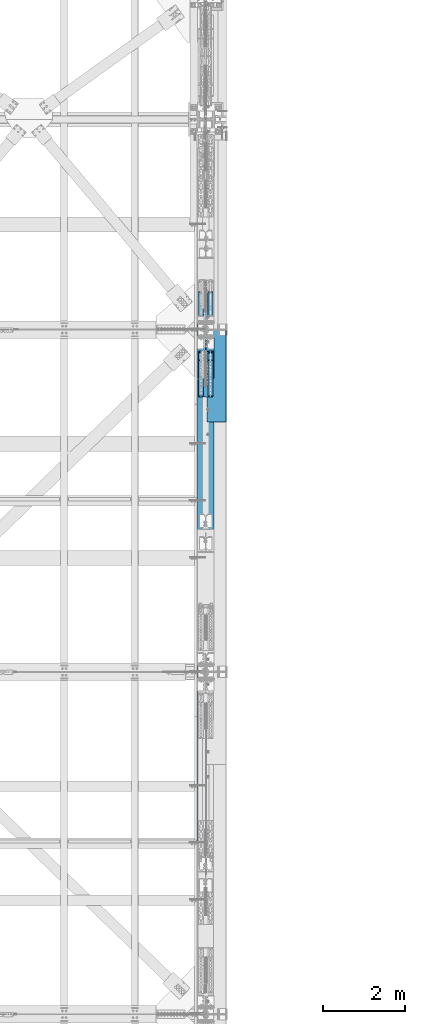
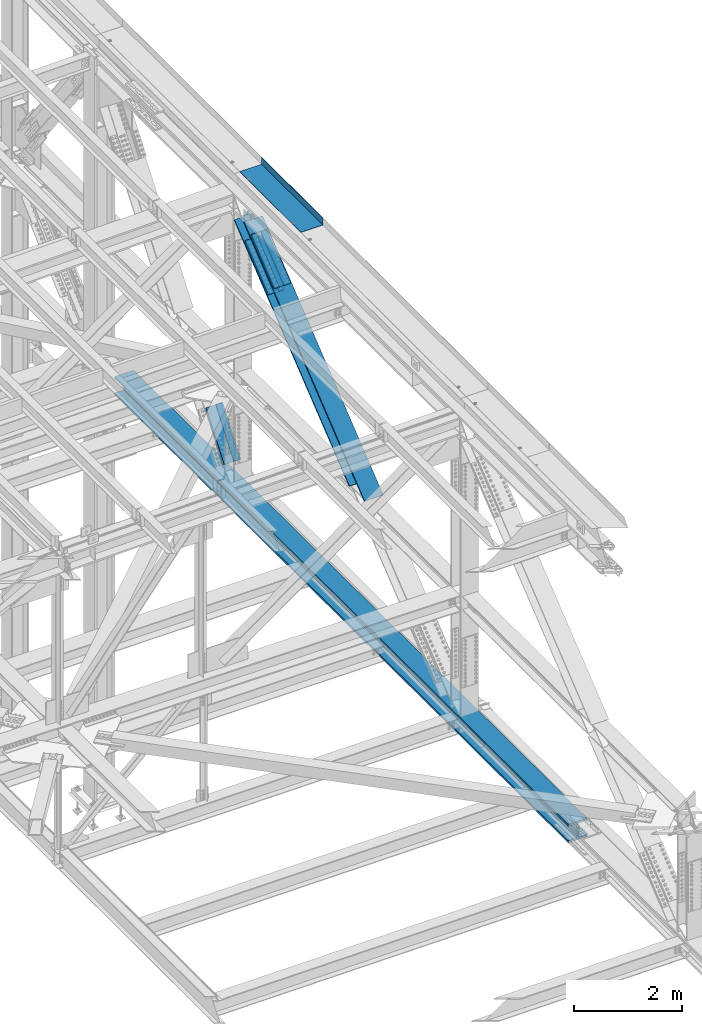
# One storey, part 1985 of 3843: 11 members, 2 beams, 4 elements without a shape of their own.
"""IFC2X3 building model written with IfcOpenShell, lengths in millimetres."""

from ifc_helpers import new_model, si_unit, frame, origin_with_axes, place, context, subcontext, project, spatial, faceted_brep, material, type_object, element, aggregate, save


model = new_model("IFC2X3")

# Units and contexts
model_context = context("Model", 3, precision=1e-05, world=origin_with_axes())
body_context = subcontext(model_context, "Body", "Model", "MODEL_VIEW")
ifc_project = project(units=[si_unit("LENGTHUNIT", "METRE", prefix="MILLI"), si_unit("AREAUNIT", "SQUARE_METRE"), si_unit("VOLUMEUNIT", "CUBIC_METRE"), si_unit("MASSUNIT", "GRAM", prefix="KILO"), si_unit("TIMEUNIT", "SECOND"), si_unit("PLANEANGLEUNIT", "RADIAN"), si_unit("SOLIDANGLEUNIT", "STERADIAN"), si_unit("THERMODYNAMICTEMPERATUREUNIT", "DEGREE_CELSIUS"), si_unit("LUMINOUSINTENSITYUNIT", "LUMEN")], contexts=[model_context])

# Site, building, storey
site_placement = place(None, origin_with_axes())
site = spatial("IfcSite", under=ifc_project, at=site_placement, CompositionType="ELEMENT")
building_placement = place(site_placement, origin_with_axes())
building = spatial("IfcBuilding", under=site, at=building_placement, Name="Undefined", CompositionType="ELEMENT")
storey_placement = place(building_placement, origin_with_axes())
storey = spatial("IfcBuildingStorey", under=building, at=storey_placement, Name="Undefined", CompositionType="ELEMENT", Elevation=0.0)

# Assembly, beam
assembly_1_placement = place(storey_placement, origin_with_axes())
assembly_1 = element("IfcElementAssembly", 1, at=assembly_1_placement, inside=storey, Name="BEAM", AssemblyPlace="NOTDEFINED", PredefinedType="RIGID_FRAME")
ifc_material_1 = material(Name="STEEL/A992")
beam_type_1 = type_object("IfcBeamType", Name="W14X257", PredefinedType="NOTDEFINED")
beam_1_placement = place(assembly_1_placement, frame((85648.8, 71449.7644305582, 39539.4404782484), z_axis=(0.0, 0.00349392500078829, 0.999993896225416), x_axis=(0.0, 0.999993896225416, -0.00349392500078778)))
beam_1 = element("IfcBeam", 2, at=beam_1_placement, type_object=beam_type_1, material=ifc_material_1, Name="BEAM", ObjectType="W14X257", context=body_context, shape_type="Brep", body=[
    faceted_brep([(13400.7918144194, -203.199999999997, 164.088281632765), (13400.7918144194, -15.0812500000029, 164.088281632765), (15075.9184465029, -15.0812500000029, 162.447245856085), (15075.9184465029, -203.199999999997, 162.447245856085), (11725.6647886285, -203.199999999997, 165.26045013847), (11725.6647886285, -15.0812500000029, 165.26045013847), (10050.537500366, -203.199999999997, 165.963751280062), (10050.537500366, -15.0812500000029, 165.963751280062), (8375.41008086779, -203.199999999997, 166.198185003552), (8375.41008086779, -15.0812500000029, 166.198185003552), (6700.28266136955, -203.199999999997, 165.963751289346), (6700.28266136955, -15.0812500000029, 165.963751289346), (5025.1553731071, -203.199999999997, 165.260450157024), (5025.1553731071, -15.0812500000029, 165.260450157024), (3350.02834731621, -203.199999999997, 164.088281660603), (3350.02834731621, -15.0812500000029, 164.088281660603), (1674.90171523266, -203.199999999997, 162.447245893207), (1674.90171523266, -15.0812500000029, 162.447245893207), (6.12560524529545, -203.199999999997, 160.345341113098), (6.12560524529545, -15.0812500000029, 160.345341113098), (13400.7918144194, 15.0812500000029, 164.088281632765), (13400.7918144194, 203.199999999997, 164.088281632765), (15075.9184465029, 203.199999999997, 162.447245856085), (15075.9184465029, 15.0812500000029, 162.447245856085), (11725.6647886285, 15.0812500000029, 165.26045013847), (11725.6647886285, 203.199999999997, 165.26045013847), (10050.537500366, 15.0812500000029, 165.963751280062), (10050.537500366, 203.199999999997, 165.963751280062), (8375.41008086779, 15.0812500000029, 166.198185003552), (8375.41008086779, 203.199999999997, 166.198185003552), (6700.28266136955, 15.0812500000029, 165.963751289346), (6700.28266136955, 203.199999999997, 165.963751289346), (5025.1553731071, 15.0812500000029, 165.260450157024), (5025.1553731071, 203.199999999997, 165.260450157024), (3350.02834731621, 15.0812500000029, 164.088281660603), (3350.02834731621, 203.199999999997, 164.088281660603), (1674.90171523266, 15.0812500000029, 162.447245893207), (1674.90171523266, 203.199999999997, 162.447245893207), (6.12560524529545, 15.0812500000029, 160.345341113098), (6.12560524529545, 203.199999999997, 160.345341113098), (13400.5225440723, 203.199999999997, -156.586605315169), (13400.5225440723, 15.0812500000029, -156.586605315169), (15075.5594194066, 15.0812500000029, -158.227553161756), (15075.5594194066, 203.199999999997, -158.227553161756), (11725.4852750518, 203.199999999997, -155.41449961668), (11725.4852750518, 15.0812500000029, -155.41449961668), (10050.4477435737, 203.199999999997, -154.711236159405), (10050.4477435737, 15.0812500000029, -154.711236159405), (8375.4100808669, 203.199999999997, -154.476814997368), (8375.4100808669, 15.0812500000029, -154.476814997368), (6700.37241816011, 203.199999999997, -154.71123615012), (6700.37241816011, 15.0812500000029, -154.71123615012), (5025.33488668206, 203.199999999997, -155.414499598119), (5025.33488668206, 15.0812500000029, -155.414499598119), (3350.29761766152, 203.199999999997, -156.586605287324), (3350.29761766152, 15.0812500000029, -156.586605287324), (1675.26074232721, 203.199999999997, -158.227553124634), (1675.26074232721, 15.0812500000029, -158.227553124634), (6.57438513686066, 203.199999999997, -160.329344856727), (6.57438513686066, 15.0812500000029, -160.329344856727), (13400.4825534267, -203.199999999997, -204.211588525264), (13400.4825534267, 203.199999999997, -204.211588525264), (15075.5060985507, 203.199999999997, -205.852523312911), (15075.5060985507, -203.199999999997, -205.852523312911), (11725.4586146196, -203.199999999997, -203.039492154574), (11725.4586146196, 203.199999999997, -203.039492154574), (10050.434413357, -203.199999999997, -202.336234293987), (10050.434413357, 203.199999999997, -202.336234293987), (8375.41008086677, -203.199999999997, -202.101814997499), (8375.41008086677, 203.199999999997, -202.101814997499), (6700.38574837653, -203.199999999997, -202.336234284703), (6700.38574837653, 203.199999999997, -202.336234284703), (5025.36154711401, -203.199999999997, -203.039492136013), (5025.36154711401, 203.199999999997, -203.039492136013), (3350.33760830687, -203.199999999997, -204.211588497419), (3350.33760830687, 203.199999999997, -204.211588497419), (1675.31406318286, -203.199999999997, -205.852523275797), (1675.31406318286, 203.199999999997, -205.852523275797), (6.64103561578668, -203.199999999997, -207.954298218574), (6.64103561578668, 203.199999999997, -207.954298218574), (13400.5225440723, -15.0812500000029, -156.586605315169), (13400.5225440723, -203.199999999997, -156.586605315169), (15075.5594194066, -203.199999999997, -158.227553161756), (15075.5594194066, -15.0812500000029, -158.227553161756), (11725.4852750518, -15.0812500000029, -155.41449961668), (11725.4852750518, -203.199999999997, -155.41449961668), (10050.4477435737, -15.0812500000029, -154.711236159405), (10050.4477435737, -203.199999999997, -154.711236159405), (8375.4100808669, -15.0812500000029, -154.476814997368), (8375.4100808669, -203.199999999997, -154.476814997368), (6700.37241816011, -15.0812500000029, -154.71123615012), (6700.37241816011, -203.199999999997, -154.71123615012), (5025.33488668206, -15.0812500000029, -155.414499598119), (5025.33488668206, -203.199999999997, -155.414499598119), (3350.29761766152, -15.0812500000029, -156.586605287324), (3350.29761766152, -203.199999999997, -156.586605287324), (1675.26074232721, -15.0812500000029, -158.227553124634), (1675.26074232721, -203.199999999997, -158.227553124634), (6.57438513686066, -15.0812500000029, -160.329344856727), (6.57438513686066, -203.199999999997, -160.329344856727), (6.05895476636942, -203.199999999997, 207.970294474952), (6.05895476636942, 203.199999999997, 207.970294474952), (1674.84839437701, -203.199999999997, 210.072216044369), (1674.84839437701, 203.199999999997, 210.072216044369), (3349.98835667086, -203.199999999997, 211.71326487069), (3349.98835667086, 203.199999999997, 211.71326487069), (5025.12871267518, -203.199999999997, 212.885442694918), (5025.12871267518, 203.199999999997, 212.885442694918), (6700.26933115313, -203.199999999997, 213.588749423921), (6700.26933115313, 203.199999999997, 213.588749423921), (8375.41008086794, -203.199999999997, 213.823185003683), (8375.41008086794, 203.199999999997, 213.823185003683), (10050.5508305827, -203.199999999997, 213.588749414637), (10050.5508305827, 203.199999999997, 213.588749414637), (11725.6914490607, -203.199999999997, 212.88544267635), (11725.6914490607, 203.199999999997, 212.88544267635), (13400.831805065, -203.199999999997, 211.713264842845), (13400.831805065, 203.199999999997, 211.713264842845), (15075.9717673588, -203.199999999997, 210.072216007247), (15075.9717673588, 203.199999999997, 210.072216007247), (16744.7612150182, -203.199999999997, 207.970294418446), (16744.7612150182, 203.199999999997, 207.970294418446), (16744.6945213029, 203.199999999997, 160.345341111053), (16744.6945213029, 15.0812500000029, 160.345341111053), (16744.2454502866, 15.0812500000029, -160.329344492086), (16744.2454502866, 203.199999999997, -160.329344492086), (16744.1787565713, 203.199999999997, -207.954297799486), (16744.1787565713, -203.199999999997, -207.954297799486), (16744.2454502866, -203.199999999997, -160.329344492086), (16744.2454502866, -15.0812500000029, -160.329344492086), (16744.6945213029, -15.0812500000029, 160.345341111053), (16744.6945213029, -203.199999999997, 160.345341111053)], [[[0, 1, 2, 3]], [[4, 5, 1, 0]], [[6, 7, 5, 4]], [[8, 9, 7, 6]], [[10, 11, 9, 8]], [[12, 13, 11, 10]], [[14, 15, 13, 12]], [[16, 17, 15, 14]], [[17, 16, 18, 19]], [[20, 21, 22, 23]], [[24, 25, 21, 20]], [[26, 27, 25, 24]], [[28, 29, 27, 26]], [[30, 31, 29, 28]], [[32, 33, 31, 30]], [[34, 35, 33, 32]], [[36, 37, 35, 34]], [[37, 36, 38, 39]], [[40, 41, 42, 43]], [[44, 45, 41, 40]], [[46, 47, 45, 44]], [[48, 49, 47, 46]], [[50, 51, 49, 48]], [[52, 53, 51, 50]], [[54, 55, 53, 52]], [[56, 57, 55, 54]], [[57, 56, 58, 59]], [[60, 61, 62, 63]], [[64, 65, 61, 60]], [[66, 67, 65, 64]], [[68, 69, 67, 66]], [[70, 71, 69, 68]], [[72, 73, 71, 70]], [[74, 75, 73, 72]], [[76, 77, 75, 74]], [[77, 76, 78, 79]], [[80, 81, 82, 83]], [[84, 85, 81, 80]], [[86, 87, 85, 84]], [[88, 89, 87, 86]], [[90, 91, 89, 88]], [[92, 93, 91, 90]], [[94, 95, 93, 92]], [[96, 97, 95, 94]], [[97, 96, 98, 99]], [[19, 18, 100, 101, 39, 38, 59, 58, 79, 78, 99, 98]], [[102, 103, 101, 100]], [[103, 102, 104, 105]], [[105, 104, 106, 107]], [[107, 106, 108, 109]], [[109, 108, 110, 111]], [[111, 110, 112, 113]], [[113, 112, 114, 115]], [[115, 114, 116, 117]], [[117, 116, 118, 119]], [[119, 118, 120, 121]], [[22, 21, 25, 27, 29, 31, 33, 35, 37, 39, 101, 103, 105, 107, 109, 111, 113, 115, 117, 119, 121, 122]], [[23, 22, 122, 123]], [[42, 41, 45, 47, 49, 51, 53, 55, 57, 59, 38, 36, 34, 32, 30, 28, 26, 24, 20, 23, 123, 124]], [[43, 42, 124, 125]], [[62, 61, 65, 67, 69, 71, 73, 75, 77, 79, 58, 56, 54, 52, 50, 48, 46, 44, 40, 43, 125, 126]], [[63, 62, 126, 127]], [[82, 81, 85, 87, 89, 91, 93, 95, 97, 99, 78, 76, 74, 72, 70, 68, 66, 64, 60, 63, 127, 128]], [[83, 82, 128, 129]], [[2, 1, 5, 7, 9, 11, 13, 15, 17, 19, 98, 96, 94, 92, 90, 88, 86, 84, 80, 83, 129, 130]], [[3, 2, 130, 131]], [[118, 116, 114, 112, 110, 108, 106, 104, 102, 100, 18, 16, 14, 12, 10, 8, 6, 4, 0, 3, 131, 120]], [[130, 129, 128, 127, 126, 125, 124, 123, 122, 121, 120, 131]]]),
])

# Assembly, members
assembly_2_placement = place(storey_placement, origin_with_axes())
assembly_2 = element("IfcElementAssembly", 3, at=assembly_2_placement, inside=storey, Name="BEAM", AssemblyPlace="NOTDEFINED", PredefinedType="RIGID_FRAME")
ifc_material_2 = material(Name="STEEL/A572-50")
member_type_1 = type_object("IfcMemberType", PredefinedType="NOTDEFINED")
member_1_placement = place(assembly_2_placement, frame((85763.1, 82563.2250123025, 44935.1767413968), z_axis=(-1.0, 0.0, 0.0), x_axis=(0.0, 0.778233356622216, 0.627975192695157)))
member_1 = element("IfcMember", 4, at=member_1_placement, type_object=member_type_1, material=ifc_material_2, Name="PLATE", context=body_context, shape_type="Brep", body=[
    faceted_brep([(-4.36557456851006e-11, 12.7000000000116, -63.5), (-4.36557456851006e-11, 12.7000000000116, 63.5), (1104.90000001677, 12.7000000017251, 63.5), (1104.90000001677, 12.7000000017251, -63.5), (1.45519152283669e-11, -12.700000000008, 63.5), (1104.90000001682, -12.6999999982909, 63.5), (1.45519152283669e-11, -12.700000000008, -63.5), (1104.90000001682, -12.6999999982909, -63.5)], [[[0, 1, 2, 3]], [[1, 4, 5, 2]], [[4, 6, 7, 5]], [[6, 0, 3, 7]], [[5, 7, 3, 2]], [[6, 4, 1, 0]]]),
])
member_2_placement = place(assembly_2_placement, frame((85763.1, 82377.7996372957, 45164.9695957562), z_axis=(-1.0, 0.0, 0.0), x_axis=(0.0, 0.778233356622216, 0.627975192695157)))
member_2 = element("IfcMember", 5, at=member_2_placement, type_object=member_type_1, material=ifc_material_2, Name="PLATE", context=body_context, shape_type="Brep", body=[
    faceted_brep([(-4.36557456851006e-11, 12.7000000000116, -63.5), (-4.36557456851006e-11, 12.7000000000116, 63.5), (1104.90000001677, 12.7000000017251, 63.5), (1104.90000001677, 12.7000000017251, -63.5), (1.45519152283669e-11, -12.700000000008, 63.5), (1104.90000001682, -12.6999999982909, 63.5), (1.45519152283669e-11, -12.700000000008, -63.5), (1104.90000001682, -12.6999999982909, -63.5)], [[[0, 1, 2, 3]], [[1, 4, 5, 2]], [[4, 6, 7, 5]], [[6, 0, 3, 7]], [[5, 7, 3, 2]], [[6, 4, 1, 0]]]),
])
member_3_placement = place(assembly_2_placement, frame((85534.5, 82563.2250123025, 44935.1767413968), z_axis=(-1.0, 0.0, 0.0), x_axis=(0.0, 0.778233356622216, 0.627975192695157)))
member_3 = element("IfcMember", 6, at=member_3_placement, type_object=member_type_1, material=ifc_material_2, Name="PLATE", context=body_context, shape_type="Brep", body=[
    faceted_brep([(-4.36557456851006e-11, 12.7000000000116, -63.5), (-4.36557456851006e-11, 12.7000000000116, 63.5), (1104.90000001677, 12.7000000017251, 63.5), (1104.90000001677, 12.7000000017251, -63.5), (1.45519152283669e-11, -12.700000000008, 63.5), (1104.90000001682, -12.6999999982909, 63.5), (1.45519152283669e-11, -12.700000000008, -63.5), (1104.90000001682, -12.6999999982909, -63.5)], [[[0, 1, 2, 3]], [[1, 4, 5, 2]], [[4, 6, 7, 5]], [[6, 0, 3, 7]], [[5, 7, 3, 2]], [[6, 4, 1, 0]]]),
])
member_4_placement = place(assembly_2_placement, frame((85534.5, 82377.7996372957, 45164.9695957562), z_axis=(-1.0, 0.0, 0.0), x_axis=(0.0, 0.778233356622216, 0.627975192695157)))
member_4 = element("IfcMember", 7, at=member_4_placement, type_object=member_type_1, material=ifc_material_2, Name="PLATE", context=body_context, shape_type="Brep", body=[
    faceted_brep([(-4.36557456851006e-11, 12.7000000000116, -63.5), (-4.36557456851006e-11, 12.7000000000116, 63.5), (1104.90000001677, 12.7000000017251, 63.5), (1104.90000001677, 12.7000000017251, -63.5), (1.45519152283669e-11, -12.700000000008, 63.5), (1104.90000001682, -12.6999999982909, 63.5), (1.45519152283669e-11, -12.700000000008, -63.5), (1104.90000001682, -12.6999999982909, -63.5)], [[[0, 1, 2, 3]], [[1, 4, 5, 2]], [[4, 6, 7, 5]], [[6, 0, 3, 7]], [[5, 7, 3, 2]], [[6, 4, 1, 0]]]),
])

# Member
member_5_placement = place(assembly_1_placement, frame((85534.5, 84909.597305123, 40959.9479836651), z_axis=(1.0, 0.0, 0.0), x_axis=(0.0, -0.605220451019692, -0.796057916025914)))
member_5 = element("IfcMember", 8, at=member_5_placement, type_object=member_type_1, material=ifc_material_2, Name="PLATE", context=body_context, shape_type="Brep", body=[
    faceted_brep([(-4.36557456851006e-11, 12.7000000000116, -63.5), (-4.36557456851006e-11, 12.7000000000116, 63.5), (1104.90000001677, 12.7000000017251, 63.5), (1104.90000001677, 12.7000000017251, -63.5), (1.45519152283669e-11, -12.700000000008, 63.5), (1104.90000001682, -12.6999999982909, 63.5), (1.45519152283669e-11, -12.700000000008, -63.5), (1104.90000001682, -12.6999999982909, -63.5)], [[[0, 1, 2, 3]], [[1, 4, 5, 2]], [[4, 6, 7, 5]], [[6, 0, 3, 7]], [[5, 7, 3, 2]], [[6, 4, 1, 0]]]),
])

member_6_placement = place(assembly_1_placement, frame((85763.1, 84909.597305123, 40959.9479836651), z_axis=(1.0, 0.0, 0.0), x_axis=(0.0, -0.605220451019692, -0.796057916025914)))
member_6 = element("IfcMember", 9, at=member_6_placement, type_object=member_type_1, material=ifc_material_2, Name="PLATE", context=body_context, shape_type="Brep", body=[
    faceted_brep([(-4.36557456851006e-11, 12.7000000000116, -63.5), (-4.36557456851006e-11, 12.7000000000116, 63.5), (1104.90000001677, 12.7000000017251, 63.5), (1104.90000001677, 12.7000000017251, -63.5), (1.45519152283669e-11, -12.700000000008, 63.5), (1104.90000001682, -12.6999999982909, 63.5), (1.45519152283669e-11, -12.700000000008, -63.5), (1104.90000001682, -12.6999999982909, -63.5)], [[[0, 1, 2, 3]], [[1, 4, 5, 2]], [[4, 6, 7, 5]], [[6, 0, 3, 7]], [[5, 7, 3, 2]], [[6, 4, 1, 0]]]),
])

member_type_2 = type_object("IfcMemberType", PredefinedType="NOTDEFINED")
member_7_placement = place(assembly_2_placement, frame((85648.8, 83457.9869214133, 45585.7859388038), z_axis=(-1.0, 0.0, 0.0), x_axis=(0.0, -0.778233356622221, -0.62797519269515)))
member_7 = element("IfcMember", 10, at=member_7_placement, type_object=member_type_2, material=ifc_material_2, Name="PLATE", context=body_context, shape_type="Brep", body=[
    faceted_brep([(-1.45519152283669e-11, 12.7000000000025, -177.800000000003), (-1.45519152283669e-11, 12.7000000000025, 177.800000000003), (1104.90000001682, 12.7000000017051, 177.800000000003), (1104.90000001682, 12.7000000017051, -177.800000000003), (4.36557456851006e-11, -12.7000000000171, 177.800000000003), (1104.90000001686, -12.6999999983072, 177.800000000003), (4.36557456851006e-11, -12.7000000000171, -177.800000000003), (1104.90000001686, -12.6999999983072, -177.800000000003)], [[[0, 1, 2, 3]], [[1, 4, 5, 2]], [[4, 6, 7, 5]], [[6, 0, 3, 7]], [[5, 7, 3, 2]], [[6, 4, 1, 0]]]),
])

member_8_placement = place(assembly_2_placement, frame((85648.8, 83202.7778011492, 45902.059977359), z_axis=(-1.0, 0.0, 0.0), x_axis=(0.0, -0.778233356622221, -0.62797519269515)))
member_8 = element("IfcMember", 11, at=member_8_placement, type_object=member_type_2, material=ifc_material_2, Name="PLATE", context=body_context, shape_type="Brep", body=[
    faceted_brep([(-1.45519152283669e-11, 12.7000000000025, -177.800000000003), (-1.45519152283669e-11, 12.7000000000025, 177.800000000003), (1104.90000001682, 12.7000000017051, 177.800000000003), (1104.90000001682, 12.7000000017051, -177.800000000003), (4.36557456851006e-11, -12.7000000000171, 177.800000000003), (1104.90000001686, -12.6999999983072, 177.800000000003), (4.36557456851006e-11, -12.7000000000171, -177.800000000003), (1104.90000001686, -12.6999999983072, -177.800000000003)], [[[0, 1, 2, 3]], [[1, 4, 5, 2]], [[4, 6, 7, 5]], [[6, 0, 3, 7]], [[5, 7, 3, 2]], [[6, 4, 1, 0]]]),
])

member_9_placement = place(assembly_1_placement, frame((85648.8, 84196.6582608267, 40114.0111535499), z_axis=(1.0, 0.0, 0.0), x_axis=(0.0, 0.605220451019692, 0.796057916025914)))
member_9 = element("IfcMember", 12, at=member_9_placement, type_object=member_type_2, material=ifc_material_2, Name="PLATE", context=body_context, shape_type="Brep", body=[
    faceted_brep([(-1.45519152283669e-11, 12.7000000000025, -177.800000000003), (-1.45519152283669e-11, 12.7000000000025, 177.800000000003), (1104.90000001682, 12.7000000017051, 177.800000000003), (1104.90000001682, 12.7000000017051, -177.800000000003), (4.36557456851006e-11, -12.7000000000171, 177.800000000003), (1104.90000001686, -12.6999999983072, 177.800000000003), (4.36557456851006e-11, -12.7000000000171, -177.800000000003), (1104.90000001686, -12.6999999983072, -177.800000000003)], [[[0, 1, 2, 3]], [[1, 4, 5, 2]], [[4, 6, 7, 5]], [[6, 0, 3, 7]], [[5, 7, 3, 2]], [[6, 4, 1, 0]]]),
])

aggregate(assembly_1, [member_5, member_6, member_9, beam_1])

member_type_3 = type_object("IfcMemberType", Name="W14X159", PredefinedType="NOTDEFINED")
member_10_placement = place(assembly_2_placement, frame((85648.8, 82900.447342684, 45396.9980637705), z_axis=(0.0, -0.627975192695145, 0.778233356622225), x_axis=(0.0, 0.778233356622216, 0.627975192695157)))
member_10 = element("IfcMember", 13, at=member_10_placement, type_object=member_type_3, material=ifc_material_1, Name="BEAM", ObjectType="W14X159", context=body_context, shape_type="Brep", body=[
    faceted_brep([(965.143221108825, -9.52499999999418, -122.237500114428), (965.143221108825, 9.52499999999418, -122.237500114428), (1027.87683935583, 9.52499999999418, -122.23750015016), (1052.3553584347, -9.52499999999418, -122.237500164108), (960.114262894058, -9.52499999999418, -123.673297234429), (960.114262894058, 9.52499999999418, -123.673297234429), (956.601433606833, -9.52499999999418, -127.547824882251), (956.601433606833, 9.52499999999418, -127.547824882251), (955.663780047267, -9.52499999999418, -132.692991536194), (955.663780047267, 9.52499999999418, -132.692991536194), (957.583985750724, -9.52499999999418, -137.55763377911), (957.583985750724, 9.52499999999418, -137.55763377911), (975.04770699385, -9.52499999999418, -160.337500005528), (975.04770699385, 9.52499999999418, -160.337500005528), (975.04770699385, 198.4375, -160.337500005528), (6.34999999470892, 198.4375, -160.337499999619), (6.34999999470892, 9.52499999999418, -160.337499999619), (997.272707002354, 9.52499999999418, -160.337500005666), (997.272707002354, 198.4375, -160.337500005666), (785.383561306255, -9.52499999999418, 137.564905430485), (785.383561306255, 9.52499999999418, 137.564905430485), (802.876529526315, 9.52499999999418, 160.337499994643), (802.876529526315, -9.52499999999418, 160.337499994643), (783.458449067228, -9.52499999999418, 132.699832888549), (783.458449067228, 9.52499999999418, 132.699832888549), (784.393401475158, -9.52499999999418, 127.551935068437), (784.393401475158, 9.52499999999418, 127.551935068437), (787.906311760642, -9.52499999999418, 123.67450688755), (787.906311760642, 9.52499999999418, 123.67450688755), (792.937216054444, -9.52499999999418, 122.237499595201), (792.937216054444, 9.52499999999418, 122.237499595201), (908.996410885724, -9.52499999999418, 122.237499774998), (878.812897485914, 9.52499999999418, 122.237499684965), (1114.62109391041, -9.52500000008149, -45.0731903553278), (1087.88143977729, 9.52499999933934, -47.8753563242026), (6.34999999323918, 9.52499999999418, 160.337499999503), (6.34999999323918, -9.52499999999418, 160.337499999503), (6.34999999470892, -9.52499999999418, -160.337499999619), (6.34999999483989, -198.4375, -190.499999999538), (6.34999999483989, 198.4375, -190.499999999538), (996.333101409487, 198.4375, -190.500000005577), (996.333101409487, -198.4375, -190.500000005577), (975.04770699385, -198.4375, -160.337500005528), (6.34999999470892, -198.4375, -160.337499999619), (997.272707002354, -198.4375, -160.337500005666), (997.272707002354, -9.52499999999418, -160.337500005666), (6.34999999323918, -198.4375, 160.337499999503), (6.34999999309366, -198.4375, 190.499999999422), (6.34999999309366, 198.4375, 190.499999999422), (6.34999999323918, 198.4375, 160.337499999503), (802.876529526315, 198.4375, 160.337499994643), (825.101529541047, 198.4375, 160.337499994504), (825.101529541047, 9.52499999999418, 160.337499994504), (825.101529541047, -9.52499999999418, 160.337499994504), (802.876529526315, -198.4375, 160.337499994643), (825.101529541047, -198.4375, 160.337499994504), (825.101529530439, -198.4375, 190.499999630465), (825.101529530453, 198.4375, 190.499999994423)], [[[0, 1, 2, 3]], [[4, 5, 1, 0]], [[6, 7, 5, 4]], [[8, 9, 7, 6]], [[10, 11, 9, 8]], [[12, 13, 11, 10]], [[14, 15, 16, 13, 17, 18]], [[19, 20, 21, 22]], [[23, 24, 20, 19]], [[25, 26, 24, 23]], [[27, 28, 26, 25]], [[29, 30, 28, 27]], [[30, 29, 31, 32]], [[32, 31, 33, 34]], [[1, 5, 7, 9, 11, 13, 16, 35, 21, 20, 24, 26, 28, 30, 32, 34, 2]], [[33, 3, 2, 34]], [[31, 29, 27, 25, 23, 19, 22, 36, 37, 12, 10, 8, 6, 4, 0, 3, 33]], [[38, 39, 40, 41]], [[42, 43, 38, 41, 44]], [[12, 37, 43, 42, 44, 45]], [[13, 12, 45, 17]], [[44, 41, 40, 18, 17, 45]], [[39, 15, 14, 18, 40]], [[38, 43, 37, 36, 46, 47, 48, 49, 35, 16, 15, 39]], [[21, 35, 49, 50, 51, 52]], [[22, 21, 52, 53]], [[54, 46, 36, 22, 53, 55]], [[47, 46, 54, 55, 56]], [[48, 47, 56, 57]], [[50, 49, 48, 57, 51]], [[56, 55, 53, 52, 51, 57]]]),
])

aggregate(assembly_2, [member_1, member_2, member_3, member_4, member_7, member_8, member_10])

# Assembly, member
assembly_3_placement = place(storey_placement, origin_with_axes())
assembly_3 = element("IfcElementAssembly", 14, at=assembly_3_placement, inside=storey, Name="V. BRACE", AssemblyPlace="NOTDEFINED", PredefinedType="RIGID_FRAME")
member_11_placement = place(assembly_3_placement, frame((85648.8, 79046.8996558819, 42287.477849714), z_axis=(0.0, -0.627975192695145, 0.778233356622225), x_axis=(0.0, 0.778233356622216, 0.627975192695157)))
member_11 = element("IfcMember", 15, at=member_11_placement, type_object=member_type_3, material=ifc_material_1, Name="V. BRACE", ObjectType="W14X159", context=body_context, shape_type="Brep", body=[
    faceted_brep([(59.3432643513952, -198.4375, 190.500000000826), (59.3432643513952, 198.4375, 190.500000000826), (59.3936498830444, 198.4375, 160.337500000755), (59.3936498830444, 9.52499999999418, 160.337500000755), (59.3936498830444, -9.52499999999418, 160.337500000755), (59.3936498830444, -198.4375, 160.337500000755), (4945.31090668582, 9.52499999999418, -160.337499966572), (4945.31090668582, 198.4375, -160.337499966572), (491.258211191205, 198.4375, -160.337499997), (491.258211191205, 9.52499999999418, -160.337499997), (491.701636513098, 198.4375, -190.499999997057), (491.701636513098, -198.4375, -190.499999997057), (491.279031130034, -198.4375, -190.157036599052), (491.279031130034, 198.4375, -190.157036599052), (4945.31090666674, 198.4375, -190.499999966636), (4945.31090666674, -198.4375, -190.499999966636), (4945.31090668582, -198.4375, -160.337499966572), (491.258211191205, -198.4375, -160.337499997), (4945.31090668582, -9.52499999999418, -160.337499966572), (491.258211191205, -9.52499999999418, -160.337499997), (532.458788148462, 9.52499999999418, -121.865768484702), (532.458788148462, -9.52499999999418, -121.865768484702), (437.442241927958, -9.52499999999418, -121.932108777797), (407.237090987051, 9.52499999999418, -121.9531979317), (536.104353032148, 9.52499999999418, -122.588270761295), (536.104353032148, -9.52499999999418, -122.588270761295), (539.195926161803, 9.52499999999418, -124.650873109033), (539.195926161803, -9.52499999999418, -124.650873109033), (541.262843553923, 9.52499999999418, -127.739563018233), (541.262843553923, -9.52499999999418, -127.739563018233), (541.990435772401, 9.52499999999418, -131.384115449557), (541.990435772401, -9.52499999999418, -131.384115449557), (542.010386769602, 9.52499999999418, -159.959108873449), (542.010386769602, -9.52499999999418, -159.959108873449), (491.257971740051, 9.52499999999418, -159.994543955767), (491.257971740051, -9.52499999999418, -159.994543955767), (4945.31090688866, 9.52499999999418, 160.337500034129), (4945.31090688866, 198.4375, 160.337500034129), (4945.31090690773, 198.4375, 190.500000034201), (4945.31090690773, -198.4375, 190.500000034201), (4945.31090688866, -198.4375, 160.337500034129), (4945.31090688866, -9.52499999999418, 160.337500034129), (60.5710414984496, -9.52499999999418, 159.381993409075), (145.665784162135, -9.52499999999418, 159.441406856644), (171.906477616882, -9.52499999999418, 138.297394415724), (175.092399316403, -9.52499999999418, 133.484306092269), (174.913809765043, -9.52499999999418, 127.71507546266), (171.436289938574, -9.52499999999418, 123.10825745649), (165.936841441595, -9.52499999999418, 121.355550260745), (137.683241427396, -9.52499999999418, 121.335823659483), (60.5710414984496, 9.52499999999418, 159.381993409075), (145.665784162135, 9.52499999999418, 159.441406856644), (171.906477616882, 9.52499999999418, 138.297394415724), (175.092399316403, 9.52499999999418, 133.484306092269), (174.913809765043, 9.52499999999418, 127.71507546266), (171.436289938574, 9.52499999999418, 123.10825745649), (165.936841441595, 9.52499999999418, 121.355550260745), (107.478170969451, 9.52499999999418, 121.314734545853)], [[[0, 1, 2, 3, 4, 5]], [[6, 7, 8, 9]], [[10, 11, 12, 13]], [[11, 10, 14, 15]], [[11, 15, 16, 17, 12]], [[16, 18, 19, 17]], [[20, 21, 22, 23]], [[21, 20, 24, 25]], [[25, 24, 26, 27]], [[27, 26, 28, 29]], [[29, 28, 30, 31]], [[31, 30, 32, 33]], [[33, 32, 34, 35]], [[9, 8, 13, 12, 17, 19, 35, 34]], [[7, 14, 10, 13, 8]], [[6, 36, 37, 38, 39, 40, 41, 18, 16, 15, 14, 7]], [[40, 39, 0, 5]], [[41, 40, 5, 4]], [[21, 25, 27, 29, 31, 33, 35, 19, 18, 41, 4, 42, 43, 44, 45, 46, 47, 48, 49, 22]], [[50, 42, 4, 3]], [[42, 50, 51, 43]], [[43, 51, 52, 44]], [[44, 52, 53, 45]], [[45, 53, 54, 46]], [[46, 54, 55, 47]], [[47, 55, 56, 48]], [[48, 56, 57, 49]], [[22, 49, 57, 23]], [[56, 55, 54, 53, 52, 51, 50, 3, 36, 6, 9, 34, 32, 30, 28, 26, 24, 20, 23, 57]], [[37, 36, 3, 2]], [[38, 37, 2, 1]], [[39, 38, 1, 0]]]),
])
aggregate(assembly_3, [member_11])

# Assembly, beam
assembly_4_placement = place(storey_placement, origin_with_axes())
assembly_4 = element("IfcElementAssembly", 16, at=assembly_4_placement, inside=storey, Name="BEAM", AssemblyPlace="NOTDEFINED", PredefinedType="RIGID_FRAME")
ifc_material_3 = material(Name="STEEL/A36")
beam_type_2 = type_object("IfcBeamType", PredefinedType="NOTDEFINED")
beam_2_placement = place(assembly_4_placement, frame((85680.5500000025, 82854.8, 46772.5125), z_axis=(0.0, -1.0, 0.0), x_axis=(1.0, 0.0, 0.0)))
beam_2 = element("IfcBeam", 17, at=beam_2_placement, type_object=beam_type_2, material=ifc_material_3, Name="BENT_PLATE", context=body_context, shape_type="Brep", body=[
    faceted_brep([(466.724999999991, 4.76249999999709, -1127.12500004766), (469.899998426787, 1.58750004768081, -1130.3), (0.0, 1.58750004768081, -1130.3), (0.0, 4.76249999999709, -1127.12500004766), (466.725000000006, 160.337499999994, -1127.12500004766), (469.899998426801, 160.337499999994, -1130.3), (0.0, 4.76249999999709, 1130.3), (466.724999999991, 4.76249999999709, 1130.3), (0.0, -4.76249999999709, -1130.3), (0.0, -4.76249999999709, 1130.3), (476.249999999985, -4.76249999999709, -1130.3), (476.249999999985, -4.76249999999709, 1130.3), (466.725000000006, 160.337499999994, 1130.3), (476.25, 160.337499999994, 1130.3), (476.25, 160.337499999994, -1130.3)], [[[0, 1, 2, 3]], [[4, 5, 1, 0]], [[6, 7, 0, 3]], [[8, 9, 6, 3, 2]], [[9, 8, 10, 11]], [[7, 12, 4, 0]], [[7, 6, 9, 11, 13, 12]], [[11, 10, 14, 13]], [[5, 14, 10, 8, 2, 1]], [[12, 13, 14, 5, 4]]]),
])
aggregate(assembly_4, [beam_2])

save(model, "model.ifc")
